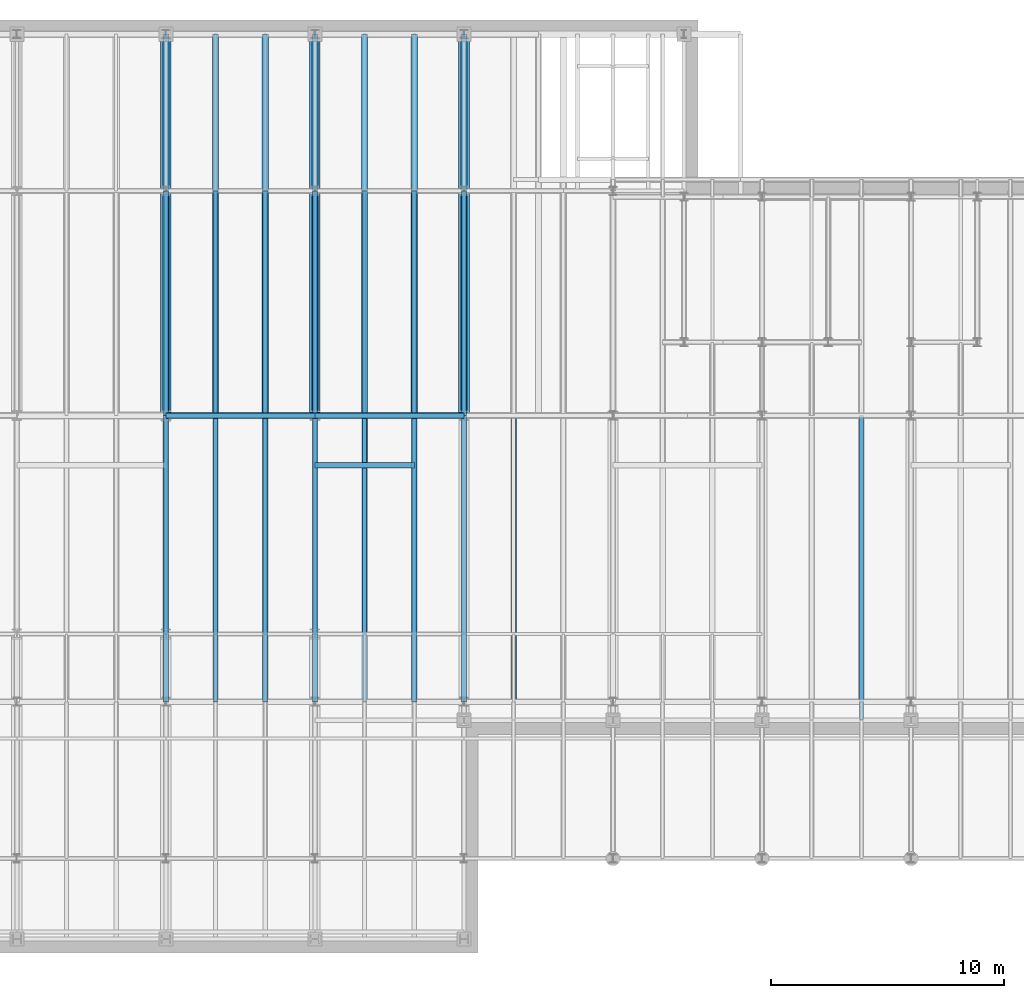
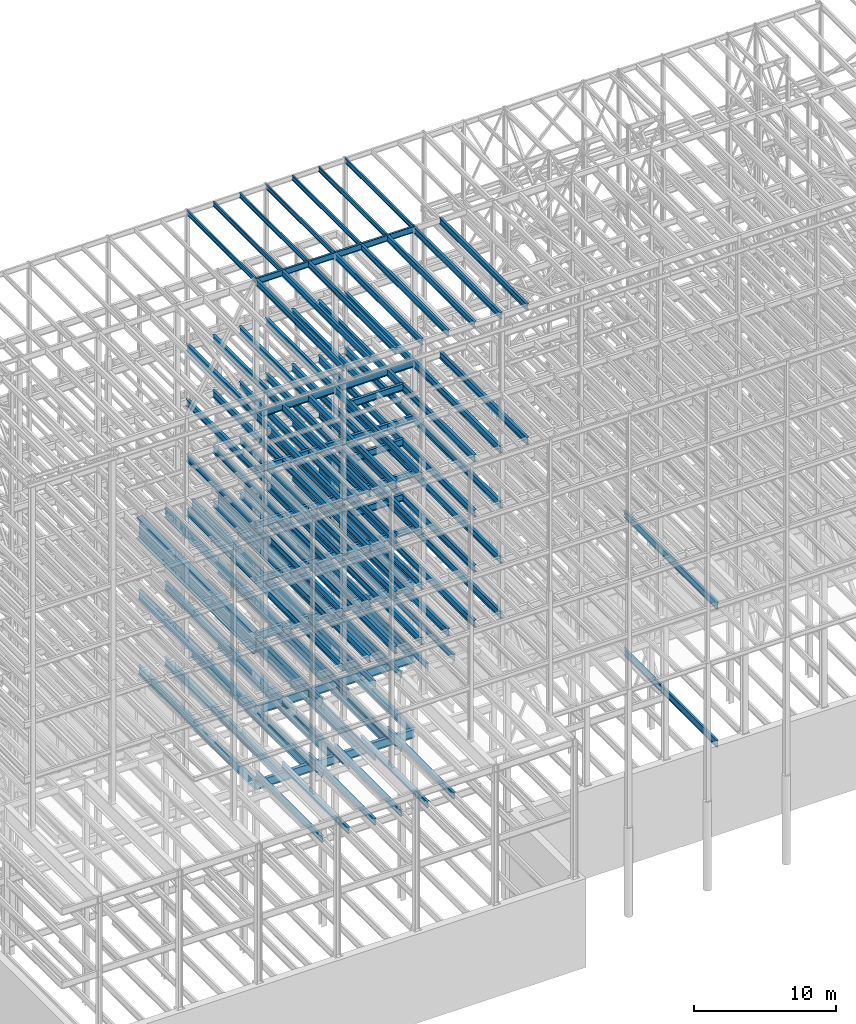
# One storey, part 131 of 150: 127 beams.
"""IFC2X3 building model written with IfcOpenShell, lengths in millimetres."""

from ifc_helpers import new_model, si_unit, frame, origin_with_axes, origin_2d_with_axis, place, context, subcontext, project, spatial, i_section, extrude, material, type_object, element, save


model = new_model("IFC2X3")

# Units and contexts
model_context = context("Model", 3, precision=1e-05, world=origin_with_axes())
body_context = subcontext(model_context, "Body", "Model", "MODEL_VIEW")
ifc_project = project(units=[si_unit("LENGTHUNIT", "METRE", prefix="MILLI"), si_unit("AREAUNIT", "SQUARE_METRE"), si_unit("VOLUMEUNIT", "CUBIC_METRE"), si_unit("MASSUNIT", "GRAM", prefix="KILO"), si_unit("TIMEUNIT", "SECOND"), si_unit("PLANEANGLEUNIT", "RADIAN"), si_unit("SOLIDANGLEUNIT", "STERADIAN"), si_unit("THERMODYNAMICTEMPERATUREUNIT", "DEGREE_CELSIUS"), si_unit("LUMINOUSINTENSITYUNIT", "LUMEN")], contexts=[model_context])

# Site, building, storey
site_placement = place(None, origin_with_axes())
site = spatial("IfcSite", under=ifc_project, at=site_placement, CompositionType="ELEMENT")
building_placement = place(site_placement, origin_with_axes())
building = spatial("IfcBuilding", under=site, at=building_placement, Name="Undefined", CompositionType="ELEMENT")
storey_placement = place(building_placement, origin_with_axes())
storey = spatial("IfcBuildingStorey", under=building, at=storey_placement, Name="Undefined", CompositionType="ELEMENT", Elevation=0.0)

# Beams
ifc_material = material(Name="STEEL/A992")
beam_type_1 = type_object("IfcBeamType", PredefinedType="NOTDEFINED")
for number, where, z_axis, x_axis, name in (
    (1, (30988.0, 22479.0, 34671.0), (0.0, 0.0, 1.0), (0.0, 1.0, 0.0), "BEAM"),
    (2, (37388.8, 22479.0, 34671.0), (0.0, 0.0, 1.0), (0.0, 1.0, 0.0), "BEAM"),
    (3, (43789.6, 22479.0, 34671.0), (0.0, 0.0, 1.0), (0.0, 1.0, 0.0), "BEAM"),
):
    element("IfcBeam", number, at=place(storey_placement, frame(where, z_axis=z_axis, x_axis=x_axis)), inside=storey, type_object=beam_type_1, material=ifc_material, Name=name, context=body_context, shape_type="SweptSolid", body=[
        extrude(i_section(OverallWidth=457.2, OverallDepth=1828.8, WebThickness=44.45, FlangeThickness=88.9, FilletRadius=31.115, at=origin_2d_with_axis()), frame((16383.0, 0.0, 0.0), z_axis=(-1.0, 0.0, 0.0), x_axis=(0.0, -1.0, 0.0)), (0.0, 0.0, 1.0), 16383.0),
    ])
beam_type_2 = type_object("IfcBeamType", Name="W16X31", PredefinedType="NOTDEFINED")
for number, where, z_axis, x_axis, name in (
    (4, (43789.6, 22479.0, 65711.3875), (0.0, 0.0, 1.0), (0.0, 1.0, 0.0), "BEAM"),
    (5, (41656.0, 22479.0, 65711.3875), (0.0, 0.0, 1.0), (0.0, 1.0, 0.0), "BEAM"),
    (6, (39522.4, 22479.0, 65711.3875), (0.0, 0.0, 1.0), (0.0, 1.0, 0.0), "BEAM"),
    (7, (37388.8, 22479.0, 65711.3875), (0.0, 0.0, 1.0), (0.0, 1.0, 0.0), "BEAM"),
    (8, (35255.2, 22479.0, 65711.3875), (0.0, 0.0, 1.0), (0.0, 1.0, 0.0), "BEAM"),
    (9, (33121.6, 22479.0, 65711.3875), (0.0, 0.0, 1.0), (0.0, 1.0, 0.0), "BEAM"),
    (10, (30988.0, 22479.0, 65711.3875), (0.0, 0.0, 1.0), (0.0, 1.0, 0.0), "BEAM"),
):
    element("IfcBeam", number, at=place(storey_placement, frame(where, z_axis=z_axis, x_axis=x_axis)), inside=storey, type_object=beam_type_2, material=ifc_material, Name=name, ObjectType="W16X31", context=body_context, shape_type="SweptSolid", body=[
        extrude(i_section(OverallWidth=140.462, OverallDepth=403.225, WebThickness=6.3499, FlangeThickness=11.176, FilletRadius=17.399, at=origin_2d_with_axis()), frame((9652.0, 0.0, 0.0), z_axis=(-1.0, 0.0, 0.0), x_axis=(0.0, -1.0, 0.0)), (0.0, 0.0, 1.0), 9652.0),
    ])
beam_type_3 = type_object("IfcBeamType", Name="W21X50", PredefinedType="NOTDEFINED")
for number, where, z_axis, x_axis, name in (
    (11, (37388.8, 22479.0, 65647.8875), (0.0, 0.0, 1.0), (1.0, 0.0, 0.0), "BEAM"),
    (12, (30988.0, 22479.0, 65647.8875), (0.0, 0.0, 1.0), (1.0, 0.0, 0.0), "BEAM"),
):
    element("IfcBeam", number, at=place(storey_placement, frame(where, z_axis=z_axis, x_axis=x_axis)), inside=storey, type_object=beam_type_3, material=ifc_material, Name=name, ObjectType="W21X50", context=body_context, shape_type="SweptSolid", body=[
        extrude(i_section(OverallWidth=165.862, OverallDepth=530.225, WebThickness=9.5249, FlangeThickness=13.589, FilletRadius=18.1609, at=origin_2d_with_axis()), frame((6400.80000000001, 0.0, 0.0), z_axis=(-1.0, 0.0, 0.0), x_axis=(0.0, -1.0, 0.0)), (0.0, 0.0, 1.0), 6400.8),
    ])
beam_type_4 = type_object("IfcBeamType", Name="W24X68", PredefinedType="NOTDEFINED")
beam_1_placement = place(storey_placement, frame((41656.0, 10185.4, 54181.375), z_axis=(0.0, 0.0, 1.0), x_axis=(0.0, 1.0, 0.0)))
element("IfcBeam", 13, at=beam_1_placement, inside=storey, type_object=beam_type_4, material=ifc_material, Name="BEAM", ObjectType="W24X68", context=body_context, shape_type="SweptSolid", body=[
    extrude(i_section(OverallWidth=227.838, OverallDepth=603.25, WebThickness=11.1125, FlangeThickness=14.859, FilletRadius=23.2409, at=origin_2d_with_axis()), frame((12293.6, 0.0, 0.0), z_axis=(-1.0, 0.0, 0.0), x_axis=(0.0, -1.0, 0.0)), (0.0, 0.0, 1.0), 12293.6),
])
beam_2_placement = place(storey_placement, frame((37388.8, 20345.4, 54181.375), z_axis=(0.0, 0.0, 1.0), x_axis=(1.0, 0.0, 0.0)))
element("IfcBeam", 14, at=beam_2_placement, inside=storey, type_object=beam_type_4, material=ifc_material, Name="BEAM", ObjectType="W24X68", context=body_context, shape_type="SweptSolid", body=[
    extrude(i_section(OverallWidth=227.838, OverallDepth=603.25, WebThickness=11.1125, FlangeThickness=14.859, FilletRadius=23.2409, at=origin_2d_with_axis()), frame((4267.20064008, 0.0, 0.0), z_axis=(-1.0, 0.0, 0.0), x_axis=(0.0, -1.0, 0.0)), (0.0, 0.0, 1.0), 4267.20064008),
])
beam_3_placement = place(storey_placement, frame((43789.6, 22479.0, 54181.375), z_axis=(0.0, 0.0, 1.0), x_axis=(0.0, 1.0, 0.0)))
element("IfcBeam", 15, at=beam_3_placement, inside=storey, type_object=beam_type_4, material=ifc_material, Name="BEAM", ObjectType="W24X68", context=body_context, shape_type="SweptSolid", body=[
    extrude(i_section(OverallWidth=227.838, OverallDepth=603.25, WebThickness=11.1125, FlangeThickness=14.859, FilletRadius=23.2409, at=origin_2d_with_axis()), frame((9652.0, 0.0, 0.0), z_axis=(-1.0, 0.0, 0.0), x_axis=(0.0, -1.0, 0.0)), (0.0, 0.0, 1.0), 9652.0),
])
beam_4_placement = place(storey_placement, frame((37388.8, 22479.0, 54181.375), z_axis=(0.0, 0.0, 1.0), x_axis=(1.0, 0.0, 0.0)))
element("IfcBeam", 16, at=beam_4_placement, inside=storey, type_object=beam_type_4, material=ifc_material, Name="BEAM", ObjectType="W24X68", context=body_context, shape_type="SweptSolid", body=[
    extrude(i_section(OverallWidth=227.838, OverallDepth=603.25, WebThickness=11.1125, FlangeThickness=14.859, FilletRadius=23.2409, at=origin_2d_with_axis()), frame((6400.79935992001, 0.0, 0.0), z_axis=(-1.0, 0.0, 0.0), x_axis=(0.0, -1.0, 0.0)), (0.0, 0.0, 1.0), 6400.79935992),
])
for number, where, z_axis, x_axis, name in (
    (17, (41656.0, 22479.0, 54181.375), (0.0, 0.0, 1.0), (0.0, 1.0, 0.0), "BEAM"),
    (18, (39522.4, 22479.0, 54181.375), (0.0, 0.0, 1.0), (0.0, 1.0, 0.0), "BEAM"),
    (19, (37388.8, 22479.0, 54181.375), (0.0, 0.0, 1.0), (0.0, 1.0, 0.0), "BEAM"),
):
    element("IfcBeam", number, at=place(storey_placement, frame(where, z_axis=z_axis, x_axis=x_axis)), inside=storey, type_object=beam_type_4, material=ifc_material, Name=name, ObjectType="W24X68", context=body_context, shape_type="SweptSolid", body=[
        extrude(i_section(OverallWidth=227.838, OverallDepth=603.25, WebThickness=11.1125, FlangeThickness=14.859, FilletRadius=23.2409, at=origin_2d_with_axis()), frame((9652.0, 0.0, 0.0), z_axis=(-1.0, 0.0, 0.0), x_axis=(0.0, -1.0, 0.0)), (0.0, 0.0, 1.0), 9652.0),
    ])
beam_5_placement = place(storey_placement, frame((30988.0, 22479.0, 54181.375), z_axis=(0.0, 0.0, 1.0), x_axis=(1.0, 0.0, 0.0)))
element("IfcBeam", 20, at=beam_5_placement, inside=storey, type_object=beam_type_4, material=ifc_material, Name="BEAM", ObjectType="W24X68", context=body_context, shape_type="SweptSolid", body=[
    extrude(i_section(OverallWidth=227.838, OverallDepth=603.25, WebThickness=11.1125, FlangeThickness=14.859, FilletRadius=23.2409, at=origin_2d_with_axis()), frame((6400.80000000001, 0.0, 0.0), z_axis=(-1.0, 0.0, 0.0), x_axis=(0.0, -1.0, 0.0)), (0.0, 0.0, 1.0), 6400.8),
])
for number, where, z_axis, x_axis, name in (
    (21, (35255.2, 22479.0, 54181.375), (0.0, 0.0, 1.0), (0.0, 1.0, 0.0), "BEAM"),
    (22, (33121.6, 22479.0, 54181.375), (0.0, 0.0, 1.0), (0.0, 1.0, 0.0), "BEAM"),
    (23, (30988.0, 22479.0, 54181.375), (0.0, 0.0, 1.0), (0.0, 1.0, 0.0), "BEAM"),
):
    element("IfcBeam", number, at=place(storey_placement, frame(where, z_axis=z_axis, x_axis=x_axis)), inside=storey, type_object=beam_type_4, material=ifc_material, Name=name, ObjectType="W24X68", context=body_context, shape_type="SweptSolid", body=[
        extrude(i_section(OverallWidth=227.838, OverallDepth=603.25, WebThickness=11.1125, FlangeThickness=14.859, FilletRadius=23.2409, at=origin_2d_with_axis()), frame((9652.0, 0.0, 0.0), z_axis=(-1.0, 0.0, 0.0), x_axis=(0.0, -1.0, 0.0)), (0.0, 0.0, 1.0), 9652.0),
    ])
for number, where, z_axis, x_axis, name in (
    (24, (45923.2, 10185.4, 54181.375), (0.0, 0.0, 1.0), (0.0, 1.0, 0.0), "BEAM"),
    (25, (43789.6, 10185.4, 54181.375), (0.0, 0.0, 1.0), (0.0, 1.0, 0.0), "BEAM"),
    (26, (37388.8, 10185.4, 54181.375), (0.0, 0.0, 1.0), (0.0, 1.0, 0.0), "BEAM"),
    (27, (35255.2, 10185.4, 54181.375), (0.0, 0.0, 1.0), (0.0, 1.0, 0.0), "BEAM"),
    (28, (33121.6, 10185.4, 54181.375), (0.0, 0.0, 1.0), (0.0, 1.0, 0.0), "BEAM"),
    (29, (30988.0, 10185.4, 54181.375), (0.0, 0.0, 1.0), (0.0, 1.0, 0.0), "BEAM"),
    (30, (41656.0, 10185.4, 49456.975), (0.0, 0.0, 1.0), (0.0, 1.0, 0.0), "BEAM"),
):
    element("IfcBeam", number, at=place(storey_placement, frame(where, z_axis=z_axis, x_axis=x_axis)), inside=storey, type_object=beam_type_4, material=ifc_material, Name=name, ObjectType="W24X68", context=body_context, shape_type="SweptSolid", body=[
        extrude(i_section(OverallWidth=227.838, OverallDepth=603.25, WebThickness=11.1125, FlangeThickness=14.859, FilletRadius=23.2409, at=origin_2d_with_axis()), frame((12293.6, 0.0, 0.0), z_axis=(-1.0, 0.0, 0.0), x_axis=(0.0, -1.0, 0.0)), (0.0, 0.0, 1.0), 12293.6),
    ])
beam_6_placement = place(storey_placement, frame((37388.8, 20345.4, 49456.975), z_axis=(0.0, 0.0, 1.0), x_axis=(1.0, 0.0, 0.0)))
element("IfcBeam", 31, at=beam_6_placement, inside=storey, type_object=beam_type_4, material=ifc_material, Name="BEAM", ObjectType="W24X68", context=body_context, shape_type="SweptSolid", body=[
    extrude(i_section(OverallWidth=227.838, OverallDepth=603.25, WebThickness=11.1125, FlangeThickness=14.859, FilletRadius=23.2409, at=origin_2d_with_axis()), frame((4267.20064008, 0.0, 0.0), z_axis=(-1.0, 0.0, 0.0), x_axis=(0.0, -1.0, 0.0)), (0.0, 0.0, 1.0), 4267.20064008),
])
beam_7_placement = place(storey_placement, frame((43789.6, 22479.0, 49456.975), z_axis=(0.0, 0.0, 1.0), x_axis=(0.0, 1.0, 0.0)))
element("IfcBeam", 32, at=beam_7_placement, inside=storey, type_object=beam_type_4, material=ifc_material, Name="BEAM", ObjectType="W24X68", context=body_context, shape_type="SweptSolid", body=[
    extrude(i_section(OverallWidth=227.838, OverallDepth=603.25, WebThickness=11.1125, FlangeThickness=14.859, FilletRadius=23.2409, at=origin_2d_with_axis()), frame((9652.0, 0.0, 0.0), z_axis=(-1.0, 0.0, 0.0), x_axis=(0.0, -1.0, 0.0)), (0.0, 0.0, 1.0), 9652.0),
])
beam_8_placement = place(storey_placement, frame((37388.8, 22479.0, 49456.975), z_axis=(0.0, 0.0, 1.0), x_axis=(1.0, 0.0, 0.0)))
element("IfcBeam", 33, at=beam_8_placement, inside=storey, type_object=beam_type_4, material=ifc_material, Name="BEAM", ObjectType="W24X68", context=body_context, shape_type="SweptSolid", body=[
    extrude(i_section(OverallWidth=227.838, OverallDepth=603.25, WebThickness=11.1125, FlangeThickness=14.859, FilletRadius=23.2409, at=origin_2d_with_axis()), frame((6400.79935992001, 0.0, 0.0), z_axis=(-1.0, 0.0, 0.0), x_axis=(0.0, -1.0, 0.0)), (0.0, 0.0, 1.0), 6400.79935992),
])
for number, where, z_axis, x_axis, name in (
    (34, (41656.0, 22479.0, 49456.975), (0.0, 0.0, 1.0), (0.0, 1.0, 0.0), "BEAM"),
    (35, (39522.4, 22479.0, 49456.975), (0.0, 0.0, 1.0), (0.0, 1.0, 0.0), "BEAM"),
    (36, (37388.8, 22479.0, 49456.975), (0.0, 0.0, 1.0), (0.0, 1.0, 0.0), "BEAM"),
):
    element("IfcBeam", number, at=place(storey_placement, frame(where, z_axis=z_axis, x_axis=x_axis)), inside=storey, type_object=beam_type_4, material=ifc_material, Name=name, ObjectType="W24X68", context=body_context, shape_type="SweptSolid", body=[
        extrude(i_section(OverallWidth=227.838, OverallDepth=603.25, WebThickness=11.1125, FlangeThickness=14.859, FilletRadius=23.2409, at=origin_2d_with_axis()), frame((9652.0, 0.0, 0.0), z_axis=(-1.0, 0.0, 0.0), x_axis=(0.0, -1.0, 0.0)), (0.0, 0.0, 1.0), 9652.0),
    ])
beam_9_placement = place(storey_placement, frame((30988.0, 22479.0, 49456.975), z_axis=(0.0, 0.0, 1.0), x_axis=(1.0, 0.0, 0.0)))
element("IfcBeam", 37, at=beam_9_placement, inside=storey, type_object=beam_type_4, material=ifc_material, Name="BEAM", ObjectType="W24X68", context=body_context, shape_type="SweptSolid", body=[
    extrude(i_section(OverallWidth=227.838, OverallDepth=603.25, WebThickness=11.1125, FlangeThickness=14.859, FilletRadius=23.2409, at=origin_2d_with_axis()), frame((6400.80000000001, 0.0, 0.0), z_axis=(-1.0, 0.0, 0.0), x_axis=(0.0, -1.0, 0.0)), (0.0, 0.0, 1.0), 6400.8),
])
for number, where, z_axis, x_axis, name in (
    (38, (35255.2, 22479.0, 49456.975), (0.0, 0.0, 1.0), (0.0, 1.0, 0.0), "BEAM"),
    (39, (33121.6, 22479.0, 49456.975), (0.0, 0.0, 1.0), (0.0, 1.0, 0.0), "BEAM"),
    (40, (30988.0, 22479.0, 49456.975), (0.0, 0.0, 1.0), (0.0, 1.0, 0.0), "BEAM"),
):
    element("IfcBeam", number, at=place(storey_placement, frame(where, z_axis=z_axis, x_axis=x_axis)), inside=storey, type_object=beam_type_4, material=ifc_material, Name=name, ObjectType="W24X68", context=body_context, shape_type="SweptSolid", body=[
        extrude(i_section(OverallWidth=227.838, OverallDepth=603.25, WebThickness=11.1125, FlangeThickness=14.859, FilletRadius=23.2409, at=origin_2d_with_axis()), frame((9652.0, 0.0, 0.0), z_axis=(-1.0, 0.0, 0.0), x_axis=(0.0, -1.0, 0.0)), (0.0, 0.0, 1.0), 9652.0),
    ])
for number, where, z_axis, x_axis, name in (
    (41, (43789.6, 10185.4, 49456.975), (0.0, 0.0, 1.0), (0.0, 1.0, 0.0), "BEAM"),
    (42, (37388.8, 10185.4, 49456.975), (0.0, 0.0, 1.0), (0.0, 1.0, 0.0), "BEAM"),
    (43, (35255.2, 10185.4, 49456.975), (0.0, 0.0, 1.0), (0.0, 1.0, 0.0), "BEAM"),
    (44, (33121.6, 10185.4, 49456.975), (0.0, 0.0, 1.0), (0.0, 1.0, 0.0), "BEAM"),
    (45, (30988.0, 10185.4, 49456.975), (0.0, 0.0, 1.0), (0.0, 1.0, 0.0), "BEAM"),
    (46, (41656.0, 10185.4, 44732.575), (0.0, 0.0, 1.0), (0.0, 1.0, 0.0), "BEAM"),
):
    element("IfcBeam", number, at=place(storey_placement, frame(where, z_axis=z_axis, x_axis=x_axis)), inside=storey, type_object=beam_type_4, material=ifc_material, Name=name, ObjectType="W24X68", context=body_context, shape_type="SweptSolid", body=[
        extrude(i_section(OverallWidth=227.838, OverallDepth=603.25, WebThickness=11.1125, FlangeThickness=14.859, FilletRadius=23.2409, at=origin_2d_with_axis()), frame((12293.6, 0.0, 0.0), z_axis=(-1.0, 0.0, 0.0), x_axis=(0.0, -1.0, 0.0)), (0.0, 0.0, 1.0), 12293.6),
    ])
beam_10_placement = place(storey_placement, frame((37388.8, 20345.4, 44732.575), z_axis=(0.0, 0.0, 1.0), x_axis=(1.0, 0.0, 0.0)))
element("IfcBeam", 47, at=beam_10_placement, inside=storey, type_object=beam_type_4, material=ifc_material, Name="BEAM", ObjectType="W24X68", context=body_context, shape_type="SweptSolid", body=[
    extrude(i_section(OverallWidth=227.838, OverallDepth=603.25, WebThickness=11.1125, FlangeThickness=14.859, FilletRadius=23.2409, at=origin_2d_with_axis()), frame((4267.20064008, 0.0, 0.0), z_axis=(-1.0, 0.0, 0.0), x_axis=(0.0, -1.0, 0.0)), (0.0, 0.0, 1.0), 4267.20064008),
])
beam_11_placement = place(storey_placement, frame((43789.6, 22479.0, 44732.575), z_axis=(0.0, 0.0, 1.0), x_axis=(0.0, 1.0, 0.0)))
element("IfcBeam", 48, at=beam_11_placement, inside=storey, type_object=beam_type_4, material=ifc_material, Name="BEAM", ObjectType="W24X68", context=body_context, shape_type="SweptSolid", body=[
    extrude(i_section(OverallWidth=227.838, OverallDepth=603.25, WebThickness=11.1125, FlangeThickness=14.859, FilletRadius=23.2409, at=origin_2d_with_axis()), frame((9652.0, 0.0, 0.0), z_axis=(-1.0, 0.0, 0.0), x_axis=(0.0, -1.0, 0.0)), (0.0, 0.0, 1.0), 9652.0),
])
beam_12_placement = place(storey_placement, frame((37388.8, 22479.0, 44732.575), z_axis=(0.0, 0.0, 1.0), x_axis=(1.0, 0.0, 0.0)))
element("IfcBeam", 49, at=beam_12_placement, inside=storey, type_object=beam_type_4, material=ifc_material, Name="BEAM", ObjectType="W24X68", context=body_context, shape_type="SweptSolid", body=[
    extrude(i_section(OverallWidth=227.838, OverallDepth=603.25, WebThickness=11.1125, FlangeThickness=14.859, FilletRadius=23.2409, at=origin_2d_with_axis()), frame((6400.79935992001, 0.0, 0.0), z_axis=(-1.0, 0.0, 0.0), x_axis=(0.0, -1.0, 0.0)), (0.0, 0.0, 1.0), 6400.79935992),
])
for number, where, z_axis, x_axis, name in (
    (50, (41656.0, 22479.0, 44732.575), (0.0, 0.0, 1.0), (0.0, 1.0, 0.0), "BEAM"),
    (51, (39522.4, 22479.0, 44732.575), (0.0, 0.0, 1.0), (0.0, 1.0, 0.0), "BEAM"),
    (52, (37388.8, 22479.0, 44732.575), (0.0, 0.0, 1.0), (0.0, 1.0, 0.0), "BEAM"),
):
    element("IfcBeam", number, at=place(storey_placement, frame(where, z_axis=z_axis, x_axis=x_axis)), inside=storey, type_object=beam_type_4, material=ifc_material, Name=name, ObjectType="W24X68", context=body_context, shape_type="SweptSolid", body=[
        extrude(i_section(OverallWidth=227.838, OverallDepth=603.25, WebThickness=11.1125, FlangeThickness=14.859, FilletRadius=23.2409, at=origin_2d_with_axis()), frame((9652.0, 0.0, 0.0), z_axis=(-1.0, 0.0, 0.0), x_axis=(0.0, -1.0, 0.0)), (0.0, 0.0, 1.0), 9652.0),
    ])
beam_13_placement = place(storey_placement, frame((30988.0, 22479.0, 44732.575), z_axis=(0.0, 0.0, 1.0), x_axis=(1.0, 0.0, 0.0)))
element("IfcBeam", 53, at=beam_13_placement, inside=storey, type_object=beam_type_4, material=ifc_material, Name="BEAM", ObjectType="W24X68", context=body_context, shape_type="SweptSolid", body=[
    extrude(i_section(OverallWidth=227.838, OverallDepth=603.25, WebThickness=11.1125, FlangeThickness=14.859, FilletRadius=23.2409, at=origin_2d_with_axis()), frame((6400.80000000001, 0.0, 0.0), z_axis=(-1.0, 0.0, 0.0), x_axis=(0.0, -1.0, 0.0)), (0.0, 0.0, 1.0), 6400.8),
])
for number, where, z_axis, x_axis, name in (
    (54, (35255.2, 22479.0, 44732.575), (0.0, 0.0, 1.0), (0.0, 1.0, 0.0), "BEAM"),
    (55, (33121.6, 22479.0, 44732.575), (0.0, 0.0, 1.0), (0.0, 1.0, 0.0), "BEAM"),
    (56, (30988.0, 22479.0, 44732.575), (0.0, 0.0, 1.0), (0.0, 1.0, 0.0), "BEAM"),
):
    element("IfcBeam", number, at=place(storey_placement, frame(where, z_axis=z_axis, x_axis=x_axis)), inside=storey, type_object=beam_type_4, material=ifc_material, Name=name, ObjectType="W24X68", context=body_context, shape_type="SweptSolid", body=[
        extrude(i_section(OverallWidth=227.838, OverallDepth=603.25, WebThickness=11.1125, FlangeThickness=14.859, FilletRadius=23.2409, at=origin_2d_with_axis()), frame((9652.0, 0.0, 0.0), z_axis=(-1.0, 0.0, 0.0), x_axis=(0.0, -1.0, 0.0)), (0.0, 0.0, 1.0), 9652.0),
    ])
for number, where, z_axis, x_axis, name in (
    (57, (43789.6, 10185.4, 44732.575), (0.0, 0.0, 1.0), (0.0, 1.0, 0.0), "BEAM"),
    (58, (37388.8, 10185.4, 44732.575), (0.0, 0.0, 1.0), (0.0, 1.0, 0.0), "BEAM"),
    (59, (35255.2, 10185.4, 44732.575), (0.0, 0.0, 1.0), (0.0, 1.0, 0.0), "BEAM"),
    (60, (33121.6, 10185.4, 44732.575), (0.0, 0.0, 1.0), (0.0, 1.0, 0.0), "BEAM"),
    (61, (30988.0, 10185.4, 44732.575), (0.0, 0.0, 1.0), (0.0, 1.0, 0.0), "BEAM"),
):
    element("IfcBeam", number, at=place(storey_placement, frame(where, z_axis=z_axis, x_axis=x_axis)), inside=storey, type_object=beam_type_4, material=ifc_material, Name=name, ObjectType="W24X68", context=body_context, shape_type="SweptSolid", body=[
        extrude(i_section(OverallWidth=227.838, OverallDepth=603.25, WebThickness=11.1125, FlangeThickness=14.859, FilletRadius=23.2409, at=origin_2d_with_axis()), frame((12293.6, 0.0, 0.0), z_axis=(-1.0, 0.0, 0.0), x_axis=(0.0, -1.0, 0.0)), (0.0, 0.0, 1.0), 12293.6),
    ])
beam_14_placement = place(storey_placement, frame((43789.6, 22479.0, 40008.175), z_axis=(0.0, 0.0, 1.0), x_axis=(0.0, 1.0, 0.0)))
element("IfcBeam", 62, at=beam_14_placement, inside=storey, type_object=beam_type_4, material=ifc_material, Name="BEAM", ObjectType="W24X68", context=body_context, shape_type="SweptSolid", body=[
    extrude(i_section(OverallWidth=227.838, OverallDepth=603.25, WebThickness=11.1125, FlangeThickness=14.859, FilletRadius=23.2409, at=origin_2d_with_axis()), frame((9652.0, 0.0, 0.0), z_axis=(-1.0, 0.0, 0.0), x_axis=(0.0, -1.0, 0.0)), (0.0, 0.0, 1.0), 9652.0),
])
beam_15_placement = place(storey_placement, frame((37388.8, 22479.0, 40008.175), z_axis=(0.0, 0.0, 1.0), x_axis=(1.0, 0.0, 0.0)))
element("IfcBeam", 63, at=beam_15_placement, inside=storey, type_object=beam_type_4, material=ifc_material, Name="BEAM", ObjectType="W24X68", context=body_context, shape_type="SweptSolid", body=[
    extrude(i_section(OverallWidth=227.838, OverallDepth=603.25, WebThickness=11.1125, FlangeThickness=14.859, FilletRadius=23.2409, at=origin_2d_with_axis()), frame((6400.80000000001, 0.0, 0.0), z_axis=(-1.0, 0.0, 0.0), x_axis=(0.0, -1.0, 0.0)), (0.0, 0.0, 1.0), 6400.8),
])
for number, where, z_axis, x_axis, name in (
    (64, (41656.0, 22479.0, 40008.175), (0.0, 0.0, 1.0), (0.0, 1.0, 0.0), "BEAM"),
    (65, (39522.4, 22479.0, 40008.175), (0.0, 0.0, 1.0), (0.0, 1.0, 0.0), "BEAM"),
    (66, (37388.8, 22479.0, 40008.175), (0.0, 0.0, 1.0), (0.0, 1.0, 0.0), "BEAM"),
):
    element("IfcBeam", number, at=place(storey_placement, frame(where, z_axis=z_axis, x_axis=x_axis)), inside=storey, type_object=beam_type_4, material=ifc_material, Name=name, ObjectType="W24X68", context=body_context, shape_type="SweptSolid", body=[
        extrude(i_section(OverallWidth=227.838, OverallDepth=603.25, WebThickness=11.1125, FlangeThickness=14.859, FilletRadius=23.2409, at=origin_2d_with_axis()), frame((9652.0, 0.0, 0.0), z_axis=(-1.0, 0.0, 0.0), x_axis=(0.0, -1.0, 0.0)), (0.0, 0.0, 1.0), 9652.0),
    ])
beam_16_placement = place(storey_placement, frame((30988.0, 22479.0, 40008.175), z_axis=(0.0, 0.0, 1.0), x_axis=(1.0, 0.0, 0.0)))
element("IfcBeam", 67, at=beam_16_placement, inside=storey, type_object=beam_type_4, material=ifc_material, Name="BEAM", ObjectType="W24X68", context=body_context, shape_type="SweptSolid", body=[
    extrude(i_section(OverallWidth=227.838, OverallDepth=603.25, WebThickness=11.1125, FlangeThickness=14.859, FilletRadius=23.2409, at=origin_2d_with_axis()), frame((6400.80000000001, 0.0, 0.0), z_axis=(-1.0, 0.0, 0.0), x_axis=(0.0, -1.0, 0.0)), (0.0, 0.0, 1.0), 6400.8),
])
for number, where, z_axis, x_axis, name in (
    (68, (35255.2, 22479.0, 40008.175), (0.0, 0.0, 1.0), (0.0, 1.0, 0.0), "BEAM"),
    (69, (33121.6, 22479.0, 40008.175), (0.0, 0.0, 1.0), (0.0, 1.0, 0.0), "BEAM"),
    (70, (30988.0, 22479.0, 40008.175), (0.0, 0.0, 1.0), (0.0, 1.0, 0.0), "BEAM"),
):
    element("IfcBeam", number, at=place(storey_placement, frame(where, z_axis=z_axis, x_axis=x_axis)), inside=storey, type_object=beam_type_4, material=ifc_material, Name=name, ObjectType="W24X68", context=body_context, shape_type="SweptSolid", body=[
        extrude(i_section(OverallWidth=227.838, OverallDepth=603.25, WebThickness=11.1125, FlangeThickness=14.859, FilletRadius=23.2409, at=origin_2d_with_axis()), frame((9652.0, 0.0, 0.0), z_axis=(-1.0, 0.0, 0.0), x_axis=(0.0, -1.0, 0.0)), (0.0, 0.0, 1.0), 9652.0),
    ])
for number, where, z_axis, x_axis, name in (
    (71, (43789.6, 10185.4, 40008.175), (0.0, 0.0, 1.0), (0.0, 1.0, 0.0), "BEAM"),
    (72, (41656.0, 10185.4, 40008.175), (0.0, 0.0, 1.0), (0.0, 1.0, 0.0), "BEAM"),
    (73, (39522.4, 10185.4, 40008.175), (0.0, 0.0, 1.0), (0.0, 1.0, 0.0), "BEAM"),
    (74, (37388.8, 10185.4, 40008.175), (0.0, 0.0, 1.0), (0.0, 1.0, 0.0), "BEAM"),
    (75, (35255.2, 10185.4, 40008.175), (0.0, 0.0, 1.0), (0.0, 1.0, 0.0), "BEAM"),
    (76, (33121.6, 10185.4, 40008.175), (0.0, 0.0, 1.0), (0.0, 1.0, 0.0), "BEAM"),
    (77, (30988.0, 10185.4, 40008.175), (0.0, 0.0, 1.0), (0.0, 1.0, 0.0), "BEAM"),
):
    element("IfcBeam", number, at=place(storey_placement, frame(where, z_axis=z_axis, x_axis=x_axis)), inside=storey, type_object=beam_type_4, material=ifc_material, Name=name, ObjectType="W24X68", context=body_context, shape_type="SweptSolid", body=[
        extrude(i_section(OverallWidth=227.838, OverallDepth=603.25, WebThickness=11.1125, FlangeThickness=14.859, FilletRadius=23.2409, at=origin_2d_with_axis()), frame((12293.6, 0.0, 0.0), z_axis=(-1.0, 0.0, 0.0), x_axis=(0.0, -1.0, 0.0)), (0.0, 0.0, 1.0), 12293.6),
    ])
beam_type_5 = type_object("IfcBeamType", Name="W21X55", PredefinedType="NOTDEFINED")
for number, where, z_axis, x_axis, name in (
    (78, (35255.2, 10185.4, 65649.475), (0.0, 0.0, 1.0), (0.0, 1.0, 0.0), "BEAM"),
    (79, (33121.6, 10185.4, 65649.475), (0.0, 0.0, 1.0), (0.0, 1.0, 0.0), "BEAM"),
    (80, (30988.0, 10185.4, 65649.475), (0.0, 0.0, 1.0), (0.0, 1.0, 0.0), "BEAM"),
    (81, (41656.0, 10185.4, 65649.475), (0.0, 0.0, 1.0), (0.0, 1.0, 0.0), "BEAM"),
    (82, (39522.4, 10185.4, 65649.475), (0.0, 0.0, 1.0), (0.0, 1.0, 0.0), "BEAM"),
    (83, (37388.8, 10185.4, 65649.475), (0.0, 0.0, 1.0), (0.0, 1.0, 0.0), "BEAM"),
    (84, (45923.2, 10185.4, 65649.475), (0.0, 0.0, 1.0), (0.0, 1.0, 0.0), "BEAM"),
    (85, (43789.6, 10185.4, 65649.475), (0.0, 0.0, 1.0), (0.0, 1.0, 0.0), "BEAM"),
):
    element("IfcBeam", number, at=place(storey_placement, frame(where, z_axis=z_axis, x_axis=x_axis)), inside=storey, type_object=beam_type_5, material=ifc_material, Name=name, ObjectType="W21X55", context=body_context, shape_type="SweptSolid", body=[
        extrude(i_section(OverallWidth=208.788, OverallDepth=527.05, WebThickness=9.5, FlangeThickness=13.2588, FilletRadius=16.8624, at=origin_2d_with_axis()), frame((12293.6, 0.0, 0.0), z_axis=(-1.0, 0.0, 0.0), x_axis=(0.0, -1.0, 0.0)), (0.0, 0.0, 1.0), 12293.6),
    ])
beam_type_6 = type_object("IfcBeamType", Name="W21X44", PredefinedType="NOTDEFINED")
for number, where, z_axis, x_axis, name in (
    (86, (30988.0, 13106.4, 35323.4625), (0.0, 0.0, 1.0), (0.0, 1.0, 0.0), "BEAM"),
    (87, (33121.6, 13106.4, 35323.4625), (0.0, 0.0, 1.0), (0.0, 1.0, 0.0), "BEAM"),
    (88, (35255.2, 13106.4, 35323.4625), (0.0, 0.0, 1.0), (0.0, 1.0, 0.0), "BEAM"),
    (89, (37388.8, 13106.4, 35323.4625), (0.0, 0.0, 1.0), (0.0, 1.0, 0.0), "BEAM"),
    (90, (39522.4, 13106.4, 35323.4625), (0.0, 0.0, 1.0), (0.0, 1.0, 0.0), "BEAM"),
    (91, (41656.0, 13106.4, 35323.4625), (0.0, 0.0, 1.0), (0.0, 1.0, 0.0), "BEAM"),
    (92, (37388.8, 13106.4, 29024.2625), (0.0, 0.0, 1.0), (0.0, 1.0, 0.0), "BEAM"),
    (93, (35255.2, 13106.4, 29024.2625), (0.0, 0.0, 1.0), (0.0, 1.0, 0.0), "BEAM"),
    (94, (33121.6, 13106.4, 29024.2625), (0.0, 0.0, 1.0), (0.0, 1.0, 0.0), "BEAM"),
    (95, (30988.0, 13106.4, 29024.2625), (0.0, 0.0, 1.0), (0.0, 1.0, 0.0), "BEAM"),
):
    element("IfcBeam", number, at=place(storey_placement, frame(where, z_axis=z_axis, x_axis=x_axis)), inside=storey, type_object=beam_type_6, material=ifc_material, Name=name, ObjectType="W21X44", context=body_context, shape_type="SweptSolid", body=[
        extrude(i_section(OverallWidth=165.1, OverallDepth=523.875, WebThickness=9.5249, FlangeThickness=11.43, FilletRadius=17.145, at=origin_2d_with_axis()), frame((9372.6, 0.0, 0.0), z_axis=(-1.0, 0.0, 0.0), x_axis=(0.0, -1.0, 0.0)), (0.0, 0.0, 1.0), 9372.6),
    ])
beam_type_7 = type_object("IfcBeamType", Name="W24X62", PredefinedType="NOTDEFINED")
for number, where, z_axis, x_axis, name in (
    (96, (60858.4, 9398.0, 35283.775), (0.0, 0.0, 1.0), (0.0, 1.0, 0.0), "BEAM"),
    (97, (60858.4, 9398.0, 23472.775), (0.0, 0.0, 1.0), (0.0, 1.0, 0.0), "BEAM"),
):
    element("IfcBeam", number, at=place(storey_placement, frame(where, z_axis=z_axis, x_axis=x_axis)), inside=storey, type_object=beam_type_7, material=ifc_material, Name=name, ObjectType="W24X62", context=body_context, shape_type="SweptSolid", body=[
        extrude(i_section(OverallWidth=177.8, OverallDepth=603.25, WebThickness=11.1125, FlangeThickness=14.986, FilletRadius=23.114, at=origin_2d_with_axis()), frame((13081.0, 0.0, 0.0), z_axis=(-1.0, 0.0, 0.0), x_axis=(0.0, -1.0, 0.0)), (0.0, 0.0, 1.0), 13081.0),
    ])
beam_type_8 = type_object("IfcBeamType", Name="W30X90", PredefinedType="NOTDEFINED")
for number, where, z_axis, x_axis, name in (
    (98, (41656.0, 22479.0, 35210.75), (0.0, 0.0, 1.0), (0.0, 1.0, 0.0), "BEAM"),
    (99, (39522.4, 22479.0, 35210.75), (0.0, 0.0, 1.0), (0.0, 1.0, 0.0), "BEAM"),
    (100, (35255.2, 22479.0, 35210.75), (0.0, 0.0, 1.0), (0.0, 1.0, 0.0), "BEAM"),
    (101, (33121.6, 22479.0, 35210.75), (0.0, 0.0, 1.0), (0.0, 1.0, 0.0), "BEAM"),
):
    element("IfcBeam", number, at=place(storey_placement, frame(where, z_axis=z_axis, x_axis=x_axis)), inside=storey, type_object=beam_type_8, material=ifc_material, Name=name, ObjectType="W30X90", context=body_context, shape_type="SweptSolid", body=[
        extrude(i_section(OverallWidth=264.16, OverallDepth=749.3, WebThickness=12.6999, FlangeThickness=15.494, FilletRadius=22.606, at=origin_2d_with_axis()), frame((16383.0, 0.0, 0.0), z_axis=(-1.0, 0.0, 0.0), x_axis=(0.0, -1.0, 0.0)), (0.0, 0.0, 1.0), 16383.0),
    ])
for number, where, z_axis, x_axis, name in (
    (102, (37388.8, 22479.0, 35210.75), (0.0, 0.0, 1.0), (1.0, 0.0, 0.0), "BEAM"),
    (103, (30988.0, 22479.0, 35210.75), (0.0, 0.0, 1.0), (1.0, 0.0, 0.0), "BEAM"),
):
    element("IfcBeam", number, at=place(storey_placement, frame(where, z_axis=z_axis, x_axis=x_axis)), inside=storey, type_object=beam_type_8, material=ifc_material, Name=name, ObjectType="W30X90", context=body_context, shape_type="SweptSolid", body=[
        extrude(i_section(OverallWidth=264.16, OverallDepth=749.3, WebThickness=12.6999, FlangeThickness=15.494, FilletRadius=22.606, at=origin_2d_with_axis()), frame((6400.80000000001, 0.0, 0.0), z_axis=(-1.0, 0.0, 0.0), x_axis=(0.0, -1.0, 0.0)), (0.0, 0.0, 1.0), 6400.8),
    ])
for number, where, z_axis, x_axis, name in (
    (104, (43789.6, 22479.0, 28911.55), (0.0, 0.0, 1.0), (0.0, 1.0, 0.0), "BEAM"),
    (105, (41656.0, 22479.0, 28911.55), (0.0, 0.0, 1.0), (0.0, 1.0, 0.0), "BEAM"),
    (106, (39522.4, 22479.0, 28911.55), (0.0, 0.0, 1.0), (0.0, 1.0, 0.0), "BEAM"),
    (107, (37388.8, 22479.0, 28911.55), (0.0, 0.0, 1.0), (0.0, 1.0, 0.0), "BEAM"),
    (108, (35255.2, 22479.0, 28911.55), (0.0, 0.0, 1.0), (0.0, 1.0, 0.0), "BEAM"),
    (109, (33121.6, 22479.0, 28911.55), (0.0, 0.0, 1.0), (0.0, 1.0, 0.0), "BEAM"),
    (110, (30988.0, 22479.0, 28911.55), (0.0, 0.0, 1.0), (0.0, 1.0, 0.0), "BEAM"),
):
    element("IfcBeam", number, at=place(storey_placement, frame(where, z_axis=z_axis, x_axis=x_axis)), inside=storey, type_object=beam_type_8, material=ifc_material, Name=name, ObjectType="W30X90", context=body_context, shape_type="SweptSolid", body=[
        extrude(i_section(OverallWidth=264.16, OverallDepth=749.3, WebThickness=12.6999, FlangeThickness=15.494, FilletRadius=22.606, at=origin_2d_with_axis()), frame((16383.0, 0.0, 0.0), z_axis=(-1.0, 0.0, 0.0), x_axis=(0.0, -1.0, 0.0)), (0.0, 0.0, 1.0), 16383.0),
    ])
for number, where, z_axis, x_axis, name in (
    (111, (37388.8, 22479.0, 28911.55), (0.0, 0.0, 1.0), (1.0, 0.0, 0.0), "BEAM"),
    (112, (30988.0, 22479.0, 28911.55), (0.0, 0.0, 1.0), (1.0, 0.0, 0.0), "BEAM"),
):
    element("IfcBeam", number, at=place(storey_placement, frame(where, z_axis=z_axis, x_axis=x_axis)), inside=storey, type_object=beam_type_8, material=ifc_material, Name=name, ObjectType="W30X90", context=body_context, shape_type="SweptSolid", body=[
        extrude(i_section(OverallWidth=264.16, OverallDepth=749.3, WebThickness=12.6999, FlangeThickness=15.494, FilletRadius=22.606, at=origin_2d_with_axis()), frame((6400.80000000001, 0.0, 0.0), z_axis=(-1.0, 0.0, 0.0), x_axis=(0.0, -1.0, 0.0)), (0.0, 0.0, 1.0), 6400.8),
    ])
for number, where, z_axis, x_axis, name in (
    (113, (43789.6, 22479.0, 22485.35), (0.0, 0.0, 1.0), (0.0, 1.0, 0.0), "BEAM"),
    (114, (41656.0, 22479.0, 22485.35), (0.0, 0.0, 1.0), (0.0, 1.0, 0.0), "BEAM"),
    (115, (39522.4, 22479.0, 22485.35), (0.0, 0.0, 1.0), (0.0, 1.0, 0.0), "BEAM"),
    (116, (37388.8, 22479.0, 22485.35), (0.0, 0.0, 1.0), (0.0, 1.0, 0.0), "BEAM"),
    (117, (35255.2, 22479.0, 22485.35), (0.0, 0.0, 1.0), (0.0, 1.0, 0.0), "BEAM"),
    (118, (33121.6, 22479.0, 22485.35), (0.0, 0.0, 1.0), (0.0, 1.0, 0.0), "BEAM"),
    (119, (30988.0, 22479.0, 22485.35), (0.0, 0.0, 1.0), (0.0, 1.0, 0.0), "BEAM"),
):
    element("IfcBeam", number, at=place(storey_placement, frame(where, z_axis=z_axis, x_axis=x_axis)), inside=storey, type_object=beam_type_8, material=ifc_material, Name=name, ObjectType="W30X90", context=body_context, shape_type="SweptSolid", body=[
        extrude(i_section(OverallWidth=264.16, OverallDepth=749.3, WebThickness=12.6999, FlangeThickness=15.494, FilletRadius=22.606, at=origin_2d_with_axis()), frame((16383.0, 0.0, 0.0), z_axis=(-1.0, 0.0, 0.0), x_axis=(0.0, -1.0, 0.0)), (0.0, 0.0, 1.0), 16383.0),
    ])
for number, where, z_axis, x_axis, name in (
    (120, (37388.8, 22479.0, 22485.35), (0.0, 0.0, 1.0), (1.0, 0.0, 0.0), "BEAM"),
    (121, (30988.0, 22479.0, 22485.35), (0.0, 0.0, 1.0), (1.0, 0.0, 0.0), "BEAM"),
):
    element("IfcBeam", number, at=place(storey_placement, frame(where, z_axis=z_axis, x_axis=x_axis)), inside=storey, type_object=beam_type_8, material=ifc_material, Name=name, ObjectType="W30X90", context=body_context, shape_type="SweptSolid", body=[
        extrude(i_section(OverallWidth=264.16, OverallDepth=749.3, WebThickness=12.6999, FlangeThickness=15.494, FilletRadius=22.606, at=origin_2d_with_axis()), frame((6400.80000000001, 0.0, 0.0), z_axis=(-1.0, 0.0, 0.0), x_axis=(0.0, -1.0, 0.0)), (0.0, 0.0, 1.0), 6400.8),
    ])
beam_type_9 = type_object("IfcBeamType", Name="W21X73", PredefinedType="NOTDEFINED")
for number, where, z_axis, x_axis, name in (
    (122, (41656.0, 13106.4, 23504.525), (0.0, 0.0, 1.0), (0.0, 1.0, 0.0), "BEAM"),
    (123, (39522.4, 13106.4, 23504.525), (0.0, 0.0, 1.0), (0.0, 1.0, 0.0), "BEAM"),
    (124, (37388.8, 13106.4, 23504.525), (0.0, 0.0, 1.0), (0.0, 1.0, 0.0), "BEAM"),
    (125, (35255.2, 13106.4, 23504.525), (0.0, 0.0, 1.0), (0.0, 1.0, 0.0), "BEAM"),
    (126, (33121.6, 13106.4, 23504.525), (0.0, 0.0, 1.0), (0.0, 1.0, 0.0), "BEAM"),
    (127, (30988.0, 13106.4, 23504.525), (0.0, 0.0, 1.0), (0.0, 1.0, 0.0), "BEAM"),
):
    element("IfcBeam", number, at=place(storey_placement, frame(where, z_axis=z_axis, x_axis=x_axis)), inside=storey, type_object=beam_type_9, material=ifc_material, Name=name, ObjectType="W21X73", context=body_context, shape_type="SweptSolid", body=[
        extrude(i_section(OverallWidth=209.55, OverallDepth=539.75, WebThickness=11.1125, FlangeThickness=18.796, FilletRadius=17.7164, at=origin_2d_with_axis()), frame((9372.6, 0.0, 0.0), z_axis=(-1.0, 0.0, 0.0), x_axis=(0.0, -1.0, 0.0)), (0.0, 0.0, 1.0), 9372.6),
    ])

save(model, "model.ifc")
